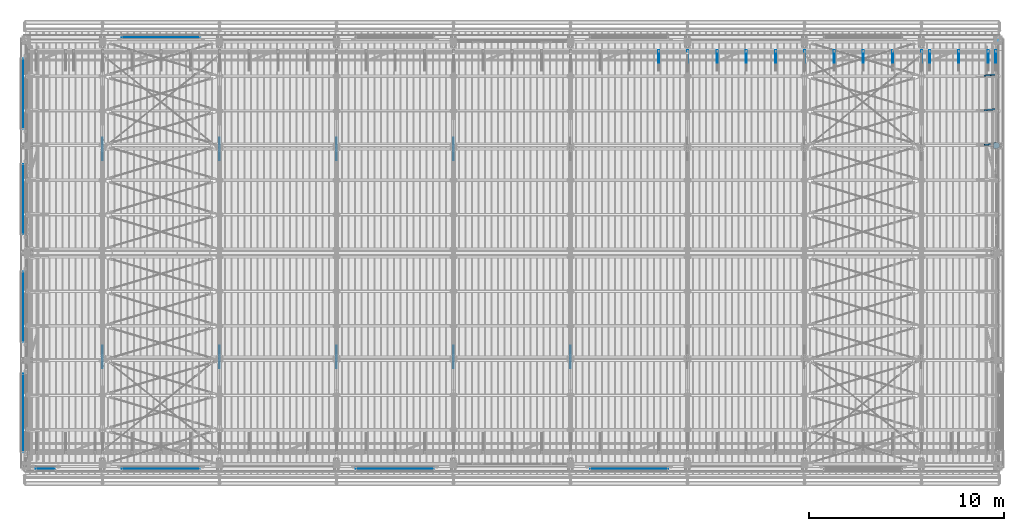
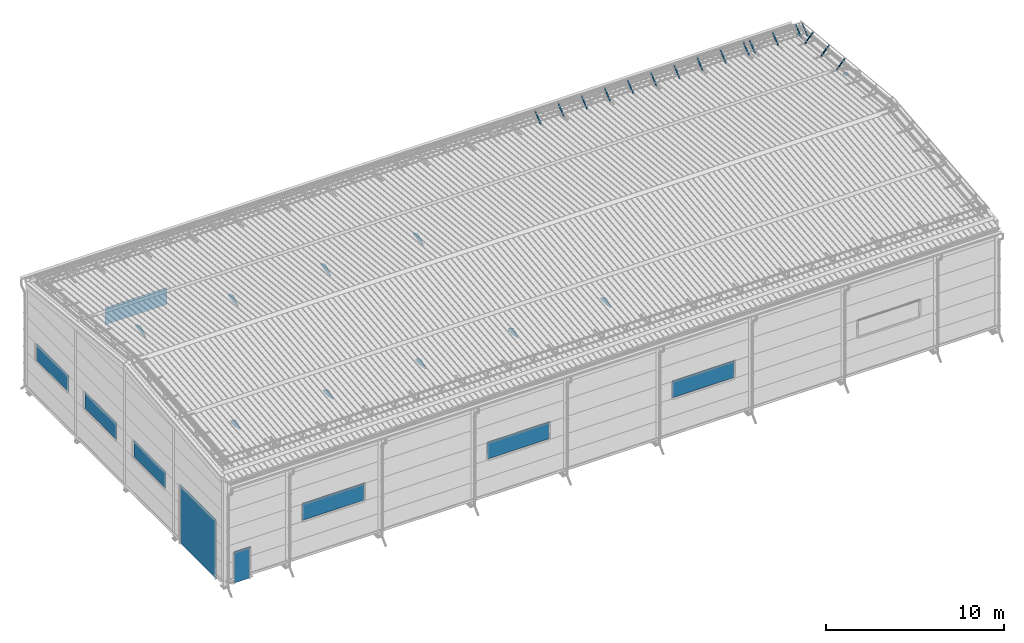
# One storey, part 105 of 709: 18 plates, 17 members, 2 beams, 37 elements without a shape of their own.
"""IFC4 building model written with IfcOpenShell, lengths in millimetres."""

from ifc_helpers import new_model, si_unit, direction, frame, origin_with_axes, place, context, subcontext, project, spatial, line, indexed_curve, outline, extrude, polygons, material, element, aggregate, save


model = new_model("IFC4")

# Units and contexts
model_context = context("Model", 3, precision=0.2, world=origin_with_axes(), true_north=direction((0.0, 1.0)))
body_context = subcontext(model_context, "Body", "Model", "MODEL_VIEW")
ifc_project = project(units=[si_unit("LENGTHUNIT", "METRE", prefix="MILLI"), si_unit("AREAUNIT", "SQUARE_METRE"), si_unit("VOLUMEUNIT", "CUBIC_METRE"), si_unit("MASSUNIT", "GRAM", prefix="KILO"), si_unit("TIMEUNIT", "SECOND"), si_unit("PLANEANGLEUNIT", "RADIAN"), si_unit("SOLIDANGLEUNIT", "STERADIAN"), si_unit("THERMODYNAMICTEMPERATUREUNIT", "DEGREE_CELSIUS"), si_unit("LUMINOUSINTENSITYUNIT", "LUMEN")], contexts=[model_context])

# Site, building, storey
site_placement = place(None, origin_with_axes())
site = spatial("IfcSite", under=ifc_project, at=site_placement, CompositionType="ELEMENT")
building_placement = place(site_placement, origin_with_axes())
building = spatial("IfcBuilding", under=site, at=building_placement, Name="Undefined", CompositionType="ELEMENT")
storey_placement = place(building_placement, origin_with_axes())
storey = spatial("IfcBuildingStorey", under=building, at=storey_placement, Name="Undefined", CompositionType="ELEMENT", Elevation=0.0)

# Assembly, beam
assembly_1_placement = place(storey_placement, frame((49920.0, 21920.0, -200.0), z_axis=(0.0, -1.0, 0.0), x_axis=(0.0, 0.0, 1.0)))
assembly_1 = element("IfcElementAssembly", 1, at=assembly_1_placement, inside=storey)
ifc_material_1 = material(Name="C355-6", Category="STEEL")
beam_1_placement = place(assembly_1_placement, frame((7216.36323, 48.5, -75.42283), z_axis=(0.9950371902, 0.0, -0.099503719), x_axis=(0.099503719, 0.0, 0.9950371902)))
beam_1 = element("IfcBeam", 2, at=beam_1_placement, material=ifc_material_1, ObjectType="454", context=body_context, shape_type="Tessellation", body=[
    polygons([(0.0, -123.5, 4.0), (0.0, 123.5, 4.0), (0.0, 123.5, -4.0), (0.0, -123.5, -4.0), (295.99751, -123.5, -4.0), (295.99751, -123.5, 4.0), (295.99751, 31.06708, 4.0), (166.2459, 123.5, 4.0), (166.2459, 123.5, -4.0), (295.99751, 31.06708, -4.0)], [[[1, 2, 3, 4]], [[1, 4, 5, 6]], [[2, 1, 6, 7, 8]], [[3, 2, 8, 9]], [[5, 4, 3, 9, 10]], [[6, 5, 10, 7]], [[9, 8, 7, 10]]], closed=True),
])
aggregate(assembly_1, [beam_1])

assembly_2_placement = place(storey_placement, frame((49851.0, 16500.0, -200.0), z_axis=(0.0, -1.0, 0.0), x_axis=(0.0, 0.0, 1.0)))
assembly_2 = element("IfcElementAssembly", 3, at=assembly_2_placement, inside=storey)
beam_2_placement = place(assembly_2_placement, frame((7777.2761, 0.0, 133.20719), z_axis=(0.9950371902, 0.0, -0.099503719), x_axis=(-0.099503719, 0.0, -0.9950371902)))
beam_2 = element("IfcBeam", 4, at=beam_2_placement, material=ifc_material_1, ObjectType="478", context=body_context, shape_type="Tessellation", body=[
    polygons([(0.0, -48.5, -6.0), (59.60596, -147.0, -6.0), (59.60596, -147.0, 6.0), (0.0, -48.5, 6.0), (0.0, 147.0, 6.0), (0.0, 147.0, -6.0), (309.74315, 147.0, 6.0), (309.74315, 147.0, -6.0), (309.74315, -48.5, 6.0), (309.74315, -48.5, -6.0), (209.3491, -147.0, -6.0), (209.3491, -147.0, 6.0)], [[[1, 2, 3, 4]], [[5, 6, 1, 4]], [[6, 5, 7, 8]], [[8, 7, 9, 10]], [[2, 1, 6, 8, 10, 11]], [[3, 2, 11, 12]], [[7, 5, 4, 3, 12, 9]], [[11, 10, 9, 12]]], closed=True),
])
aggregate(assembly_2, [beam_2])

# Assembly, member
assembly_3_placement = place(storey_placement, frame((49815.0, 20762.95162, 7589.66203), z_axis=(0.0, 0.6332377902, -0.7739572992), x_axis=(0.0, 0.7739572992, 0.6332377902)))
assembly_3 = element("IfcElementAssembly", 5, at=assembly_3_placement, inside=storey)
ifc_material_2 = material(Name="Steel_Undefined", Category="STEEL")
member_1_placement = place(assembly_3_placement, origin_with_axes())
member_1 = element("IfcMember", 6, at=member_1_placement, material=ifc_material_2, ObjectType="603", context=body_context, shape_type="Tessellation", body=[
    polygons([(0.0, -25.0, -20.0), (0.0, 25.0, -20.0), (848.52814, 25.0, -20.0), (848.52814, -25.0, -20.0), (40.0, 25.0, 20.0), (808.52814, 25.0, 20.0), (40.0, 22.5, 20.0), (808.52814, 22.5, 20.0), (2.5, 22.5, -17.5), (846.02814, 22.5, -17.5), (2.5, -22.5, -17.5), (846.02814, -22.5, -17.5), (40.0, -22.5, 20.0), (808.52814, -22.5, 20.0), (40.0, -25.0, 20.0), (808.52814, -25.0, 20.0)], [[[1, 2, 3, 4]], [[2, 5, 6, 3]], [[5, 7, 8, 6]], [[7, 9, 10, 8]], [[9, 11, 12, 10]], [[11, 13, 14, 12]], [[13, 15, 16, 14]], [[15, 1, 4, 16]], [[6, 8, 10, 12, 14, 16, 4, 3]], [[15, 13, 11, 9, 7, 5, 2, 1]]], closed=True),
])
aggregate(assembly_3, [member_1])

assembly_4_placement = place(storey_placement, frame((49415.0, 20762.95162, 7589.66203), z_axis=(0.0, 0.6332377902, -0.7739572992), x_axis=(0.0, 0.7739572992, 0.6332377902)))
assembly_4 = element("IfcElementAssembly", 7, at=assembly_4_placement, inside=storey)
member_2_placement = place(assembly_4_placement, origin_with_axes())
member_2 = element("IfcMember", 8, at=member_2_placement, material=ifc_material_2, ObjectType="603", context=body_context, shape_type="Tessellation", body=[
    polygons([(0.0, -25.0, -20.0), (0.0, 25.0, -20.0), (848.52814, 25.0, -20.0), (848.52814, -25.0, -20.0), (40.0, 25.0, 20.0), (808.52814, 25.0, 20.0), (40.0, 22.5, 20.0), (808.52814, 22.5, 20.0), (2.5, 22.5, -17.5), (846.02814, 22.5, -17.5), (2.5, -22.5, -17.5), (846.02814, -22.5, -17.5), (40.0, -22.5, 20.0), (808.52814, -22.5, 20.0), (40.0, -25.0, 20.0), (808.52814, -25.0, 20.0)], [[[1, 2, 3, 4]], [[2, 5, 6, 3]], [[5, 7, 8, 6]], [[7, 9, 10, 8]], [[9, 11, 12, 10]], [[11, 13, 14, 12]], [[13, 15, 16, 14]], [[15, 1, 4, 16]], [[6, 8, 10, 12, 14, 16, 4, 3]], [[15, 13, 11, 9, 7, 5, 2, 1]]], closed=True),
])
aggregate(assembly_4, [member_2])

assembly_5_placement = place(storey_placement, frame((47915.0, 20762.95162, 7589.66203), z_axis=(0.0, 0.6332377902, -0.7739572992), x_axis=(0.0, 0.7739572992, 0.6332377902)))
assembly_5 = element("IfcElementAssembly", 9, at=assembly_5_placement, inside=storey)
member_3_placement = place(assembly_5_placement, origin_with_axes())
member_3 = element("IfcMember", 10, at=member_3_placement, material=ifc_material_2, ObjectType="603", context=body_context, shape_type="Tessellation", body=[
    polygons([(0.0, -25.0, -20.0), (0.0, 25.0, -20.0), (848.52814, 25.0, -20.0), (848.52814, -25.0, -20.0), (40.0, 25.0, 20.0), (808.52814, 25.0, 20.0), (40.0, 22.5, 20.0), (808.52814, 22.5, 20.0), (2.5, 22.5, -17.5), (846.02814, 22.5, -17.5), (2.5, -22.5, -17.5), (846.02814, -22.5, -17.5), (40.0, -22.5, 20.0), (808.52814, -22.5, 20.0), (40.0, -25.0, 20.0), (808.52814, -25.0, 20.0)], [[[1, 2, 3, 4]], [[2, 5, 6, 3]], [[5, 7, 8, 6]], [[7, 9, 10, 8]], [[9, 11, 12, 10]], [[11, 13, 14, 12]], [[13, 15, 16, 14]], [[15, 1, 4, 16]], [[6, 8, 10, 12, 14, 16, 4, 3]], [[15, 13, 11, 9, 7, 5, 2, 1]]], closed=True),
])
aggregate(assembly_5, [member_3])

assembly_6_placement = place(storey_placement, frame((46415.0, 20762.95162, 7589.66203), z_axis=(0.0, 0.6332377902, -0.7739572992), x_axis=(0.0, 0.7739572992, 0.6332377902)))
assembly_6 = element("IfcElementAssembly", 11, at=assembly_6_placement, inside=storey)
member_4_placement = place(assembly_6_placement, origin_with_axes())
member_4 = element("IfcMember", 12, at=member_4_placement, material=ifc_material_2, ObjectType="603", context=body_context, shape_type="Tessellation", body=[
    polygons([(0.0, -25.0, -20.0), (0.0, 25.0, -20.0), (848.52814, 25.0, -20.0), (848.52814, -25.0, -20.0), (40.0, 25.0, 20.0), (808.52814, 25.0, 20.0), (40.0, 22.5, 20.0), (808.52814, 22.5, 20.0), (2.5, 22.5, -17.5), (846.02814, 22.5, -17.5), (2.5, -22.5, -17.5), (846.02814, -22.5, -17.5), (40.0, -22.5, 20.0), (808.52814, -22.5, 20.0), (40.0, -25.0, 20.0), (808.52814, -25.0, 20.0)], [[[1, 2, 3, 4]], [[2, 5, 6, 3]], [[5, 7, 8, 6]], [[7, 9, 10, 8]], [[9, 11, 12, 10]], [[11, 13, 14, 12]], [[13, 15, 16, 14]], [[15, 1, 4, 16]], [[6, 8, 10, 12, 14, 16, 4, 3]], [[15, 13, 11, 9, 7, 5, 2, 1]]], closed=True),
])
aggregate(assembly_6, [member_4])

assembly_7_placement = place(storey_placement, frame((46015.0, 20762.95162, 7589.66203), z_axis=(0.0, 0.6332377902, -0.7739572992), x_axis=(0.0, 0.7739572992, 0.6332377902)))
assembly_7 = element("IfcElementAssembly", 13, at=assembly_7_placement, inside=storey)
member_5_placement = place(assembly_7_placement, origin_with_axes())
member_5 = element("IfcMember", 14, at=member_5_placement, material=ifc_material_2, ObjectType="603", context=body_context, shape_type="Tessellation", body=[
    polygons([(0.0, -25.0, -20.0), (0.0, 25.0, -20.0), (848.52814, 25.0, -20.0), (848.52814, -25.0, -20.0), (40.0, 25.0, 20.0), (808.52814, 25.0, 20.0), (40.0, 22.5, 20.0), (808.52814, 22.5, 20.0), (2.5, 22.5, -17.5), (846.02814, 22.5, -17.5), (2.5, -22.5, -17.5), (846.02814, -22.5, -17.5), (40.0, -22.5, 20.0), (808.52814, -22.5, 20.0), (40.0, -25.0, 20.0), (808.52814, -25.0, 20.0)], [[[1, 2, 3, 4]], [[2, 5, 6, 3]], [[5, 7, 8, 6]], [[7, 9, 10, 8]], [[9, 11, 12, 10]], [[11, 13, 14, 12]], [[13, 15, 16, 14]], [[15, 1, 4, 16]], [[6, 8, 10, 12, 14, 16, 4, 3]], [[15, 13, 11, 9, 7, 5, 2, 1]]], closed=True),
])
aggregate(assembly_7, [member_5])

assembly_8_placement = place(storey_placement, frame((44515.0, 20762.95162, 7589.66203), z_axis=(0.0, 0.6332377902, -0.7739572992), x_axis=(0.0, 0.7739572992, 0.6332377902)))
assembly_8 = element("IfcElementAssembly", 15, at=assembly_8_placement, inside=storey)
member_6_placement = place(assembly_8_placement, origin_with_axes())
member_6 = element("IfcMember", 16, at=member_6_placement, material=ifc_material_2, ObjectType="603", context=body_context, shape_type="Tessellation", body=[
    polygons([(0.0, -25.0, -20.0), (0.0, 25.0, -20.0), (848.52814, 25.0, -20.0), (848.52814, -25.0, -20.0), (40.0, 25.0, 20.0), (808.52814, 25.0, 20.0), (40.0, 22.5, 20.0), (808.52814, 22.5, 20.0), (2.5, 22.5, -17.5), (846.02814, 22.5, -17.5), (2.5, -22.5, -17.5), (846.02814, -22.5, -17.5), (40.0, -22.5, 20.0), (808.52814, -22.5, 20.0), (40.0, -25.0, 20.0), (808.52814, -25.0, 20.0)], [[[1, 2, 3, 4]], [[2, 5, 6, 3]], [[5, 7, 8, 6]], [[7, 9, 10, 8]], [[9, 11, 12, 10]], [[11, 13, 14, 12]], [[13, 15, 16, 14]], [[15, 1, 4, 16]], [[6, 8, 10, 12, 14, 16, 4, 3]], [[15, 13, 11, 9, 7, 5, 2, 1]]], closed=True),
])
aggregate(assembly_8, [member_6])

assembly_9_placement = place(storey_placement, frame((43015.0, 20762.95162, 7589.66203), z_axis=(0.0, 0.6332377902, -0.7739572992), x_axis=(0.0, 0.7739572992, 0.6332377902)))
assembly_9 = element("IfcElementAssembly", 17, at=assembly_9_placement, inside=storey)
member_7_placement = place(assembly_9_placement, origin_with_axes())
member_7 = element("IfcMember", 18, at=member_7_placement, material=ifc_material_2, ObjectType="603", context=body_context, shape_type="Tessellation", body=[
    polygons([(0.0, -25.0, -20.0), (0.0, 25.0, -20.0), (848.52814, 25.0, -20.0), (848.52814, -25.0, -20.0), (40.0, 25.0, 20.0), (808.52814, 25.0, 20.0), (40.0, 22.5, 20.0), (808.52814, 22.5, 20.0), (2.5, 22.5, -17.5), (846.02814, 22.5, -17.5), (2.5, -22.5, -17.5), (846.02814, -22.5, -17.5), (40.0, -22.5, 20.0), (808.52814, -22.5, 20.0), (40.0, -25.0, 20.0), (808.52814, -25.0, 20.0)], [[[1, 2, 3, 4]], [[2, 5, 6, 3]], [[5, 7, 8, 6]], [[7, 9, 10, 8]], [[9, 11, 12, 10]], [[11, 13, 14, 12]], [[13, 15, 16, 14]], [[15, 1, 4, 16]], [[6, 8, 10, 12, 14, 16, 4, 3]], [[15, 13, 11, 9, 7, 5, 2, 1]]], closed=True),
])
aggregate(assembly_9, [member_7])

assembly_10_placement = place(storey_placement, frame((41515.0, 20762.95162, 7589.66203), z_axis=(0.0, 0.6332377902, -0.7739572992), x_axis=(0.0, 0.7739572992, 0.6332377902)))
assembly_10 = element("IfcElementAssembly", 19, at=assembly_10_placement, inside=storey)
member_8_placement = place(assembly_10_placement, origin_with_axes())
member_8 = element("IfcMember", 20, at=member_8_placement, material=ifc_material_2, ObjectType="603", context=body_context, shape_type="Tessellation", body=[
    polygons([(0.0, -25.0, -20.0), (0.0, 25.0, -20.0), (848.52814, 25.0, -20.0), (848.52814, -25.0, -20.0), (40.0, 25.0, 20.0), (808.52814, 25.0, 20.0), (40.0, 22.5, 20.0), (808.52814, 22.5, 20.0), (2.5, 22.5, -17.5), (846.02814, 22.5, -17.5), (2.5, -22.5, -17.5), (846.02814, -22.5, -17.5), (40.0, -22.5, 20.0), (808.52814, -22.5, 20.0), (40.0, -25.0, 20.0), (808.52814, -25.0, 20.0)], [[[1, 2, 3, 4]], [[2, 5, 6, 3]], [[5, 7, 8, 6]], [[7, 9, 10, 8]], [[9, 11, 12, 10]], [[11, 13, 14, 12]], [[13, 15, 16, 14]], [[15, 1, 4, 16]], [[6, 8, 10, 12, 14, 16, 4, 3]], [[15, 13, 11, 9, 7, 5, 2, 1]]], closed=True),
])
aggregate(assembly_10, [member_8])

assembly_11_placement = place(storey_placement, frame((40015.0, 20762.95162, 7589.66203), z_axis=(0.0, 0.6332377902, -0.7739572992), x_axis=(0.0, 0.7739572992, 0.6332377902)))
assembly_11 = element("IfcElementAssembly", 21, at=assembly_11_placement, inside=storey)
member_9_placement = place(assembly_11_placement, origin_with_axes())
member_9 = element("IfcMember", 22, at=member_9_placement, material=ifc_material_2, ObjectType="603", context=body_context, shape_type="Tessellation", body=[
    polygons([(0.0, -25.0, -20.0), (0.0, 25.0, -20.0), (848.52814, 25.0, -20.0), (848.52814, -25.0, -20.0), (40.0, 25.0, 20.0), (808.52814, 25.0, 20.0), (40.0, 22.5, 20.0), (808.52814, 22.5, 20.0), (2.5, 22.5, -17.5), (846.02814, 22.5, -17.5), (2.5, -22.5, -17.5), (846.02814, -22.5, -17.5), (40.0, -22.5, 20.0), (808.52814, -22.5, 20.0), (40.0, -25.0, 20.0), (808.52814, -25.0, 20.0)], [[[1, 2, 3, 4]], [[2, 5, 6, 3]], [[5, 7, 8, 6]], [[7, 9, 10, 8]], [[9, 11, 12, 10]], [[11, 13, 14, 12]], [[13, 15, 16, 14]], [[15, 1, 4, 16]], [[6, 8, 10, 12, 14, 16, 4, 3]], [[15, 13, 11, 9, 7, 5, 2, 1]]], closed=True),
])
aggregate(assembly_11, [member_9])

assembly_12_placement = place(storey_placement, frame((38515.0, 20762.95162, 7589.66203), z_axis=(0.0, 0.6332377902, -0.7739572992), x_axis=(0.0, 0.7739572992, 0.6332377902)))
assembly_12 = element("IfcElementAssembly", 23, at=assembly_12_placement, inside=storey)
member_10_placement = place(assembly_12_placement, origin_with_axes())
member_10 = element("IfcMember", 24, at=member_10_placement, material=ifc_material_2, ObjectType="603", context=body_context, shape_type="Tessellation", body=[
    polygons([(0.0, -25.0, -20.0), (0.0, 25.0, -20.0), (848.52814, 25.0, -20.0), (848.52814, -25.0, -20.0), (40.0, 25.0, 20.0), (808.52814, 25.0, 20.0), (40.0, 22.5, 20.0), (808.52814, 22.5, 20.0), (2.5, 22.5, -17.5), (846.02814, 22.5, -17.5), (2.5, -22.5, -17.5), (846.02814, -22.5, -17.5), (40.0, -22.5, 20.0), (808.52814, -22.5, 20.0), (40.0, -25.0, 20.0), (808.52814, -25.0, 20.0)], [[[1, 2, 3, 4]], [[2, 5, 6, 3]], [[5, 7, 8, 6]], [[7, 9, 10, 8]], [[9, 11, 12, 10]], [[11, 13, 14, 12]], [[13, 15, 16, 14]], [[15, 1, 4, 16]], [[6, 8, 10, 12, 14, 16, 4, 3]], [[15, 13, 11, 9, 7, 5, 2, 1]]], closed=True),
])
aggregate(assembly_12, [member_10])

assembly_13_placement = place(storey_placement, frame((37015.0, 20762.95162, 7589.66203), z_axis=(0.0, 0.6332377902, -0.7739572992), x_axis=(0.0, 0.7739572992, 0.6332377902)))
assembly_13 = element("IfcElementAssembly", 25, at=assembly_13_placement, inside=storey)
member_11_placement = place(assembly_13_placement, origin_with_axes())
member_11 = element("IfcMember", 26, at=member_11_placement, material=ifc_material_2, ObjectType="603", context=body_context, shape_type="Tessellation", body=[
    polygons([(0.0, -25.0, -20.0), (0.0, 25.0, -20.0), (848.52814, 25.0, -20.0), (848.52814, -25.0, -20.0), (40.0, 25.0, 20.0), (808.52814, 25.0, 20.0), (40.0, 22.5, 20.0), (808.52814, 22.5, 20.0), (2.5, 22.5, -17.5), (846.02814, 22.5, -17.5), (2.5, -22.5, -17.5), (846.02814, -22.5, -17.5), (40.0, -22.5, 20.0), (808.52814, -22.5, 20.0), (40.0, -25.0, 20.0), (808.52814, -25.0, 20.0)], [[[1, 2, 3, 4]], [[2, 5, 6, 3]], [[5, 7, 8, 6]], [[7, 9, 10, 8]], [[9, 11, 12, 10]], [[11, 13, 14, 12]], [[13, 15, 16, 14]], [[15, 1, 4, 16]], [[6, 8, 10, 12, 14, 16, 4, 3]], [[15, 13, 11, 9, 7, 5, 2, 1]]], closed=True),
])
aggregate(assembly_13, [member_11])

assembly_14_placement = place(storey_placement, frame((35515.0, 20762.95162, 7589.66203), z_axis=(0.0, 0.6332377902, -0.7739572992), x_axis=(0.0, 0.7739572992, 0.6332377902)))
assembly_14 = element("IfcElementAssembly", 27, at=assembly_14_placement, inside=storey)
member_12_placement = place(assembly_14_placement, origin_with_axes())
member_12 = element("IfcMember", 28, at=member_12_placement, material=ifc_material_2, ObjectType="603", context=body_context, shape_type="Tessellation", body=[
    polygons([(0.0, -25.0, -20.0), (0.0, 25.0, -20.0), (848.52814, 25.0, -20.0), (848.52814, -25.0, -20.0), (40.0, 25.0, 20.0), (808.52814, 25.0, 20.0), (40.0, 22.5, 20.0), (808.52814, 22.5, 20.0), (2.5, 22.5, -17.5), (846.02814, 22.5, -17.5), (2.5, -22.5, -17.5), (846.02814, -22.5, -17.5), (40.0, -22.5, 20.0), (808.52814, -22.5, 20.0), (40.0, -25.0, 20.0), (808.52814, -25.0, 20.0)], [[[1, 2, 3, 4]], [[2, 5, 6, 3]], [[5, 7, 8, 6]], [[7, 9, 10, 8]], [[9, 11, 12, 10]], [[11, 13, 14, 12]], [[13, 15, 16, 14]], [[15, 1, 4, 16]], [[6, 8, 10, 12, 14, 16, 4, 3]], [[15, 13, 11, 9, 7, 5, 2, 1]]], closed=True),
])
aggregate(assembly_14, [member_12])

assembly_15_placement = place(storey_placement, frame((34015.0, 20762.95162, 7589.66203), z_axis=(0.0, 0.6332377902, -0.7739572992), x_axis=(0.0, 0.7739572992, 0.6332377902)))
assembly_15 = element("IfcElementAssembly", 29, at=assembly_15_placement, inside=storey)
member_13_placement = place(assembly_15_placement, origin_with_axes())
member_13 = element("IfcMember", 30, at=member_13_placement, material=ifc_material_2, ObjectType="603", context=body_context, shape_type="Tessellation", body=[
    polygons([(0.0, -25.0, -20.0), (0.0, 25.0, -20.0), (848.52814, 25.0, -20.0), (848.52814, -25.0, -20.0), (40.0, 25.0, 20.0), (808.52814, 25.0, 20.0), (40.0, 22.5, 20.0), (808.52814, 22.5, 20.0), (2.5, 22.5, -17.5), (846.02814, 22.5, -17.5), (2.5, -22.5, -17.5), (846.02814, -22.5, -17.5), (40.0, -22.5, 20.0), (808.52814, -22.5, 20.0), (40.0, -25.0, 20.0), (808.52814, -25.0, 20.0)], [[[1, 2, 3, 4]], [[2, 5, 6, 3]], [[5, 7, 8, 6]], [[7, 9, 10, 8]], [[9, 11, 12, 10]], [[11, 13, 14, 12]], [[13, 15, 16, 14]], [[15, 1, 4, 16]], [[6, 8, 10, 12, 14, 16, 4, 3]], [[15, 13, 11, 9, 7, 5, 2, 1]]], closed=True),
])
aggregate(assembly_15, [member_13])

assembly_16_placement = place(storey_placement, frame((32515.0, 20762.95162, 7589.66203), z_axis=(0.0, 0.6332377902, -0.7739572992), x_axis=(0.0, 0.7739572992, 0.6332377902)))
assembly_16 = element("IfcElementAssembly", 31, at=assembly_16_placement, inside=storey)
member_14_placement = place(assembly_16_placement, origin_with_axes())
member_14 = element("IfcMember", 32, at=member_14_placement, material=ifc_material_2, ObjectType="603", context=body_context, shape_type="Tessellation", body=[
    polygons([(0.0, -25.0, -20.0), (0.0, 25.0, -20.0), (848.52814, 25.0, -20.0), (848.52814, -25.0, -20.0), (40.0, 25.0, 20.0), (808.52814, 25.0, 20.0), (40.0, 22.5, 20.0), (808.52814, 22.5, 20.0), (2.5, 22.5, -17.5), (846.02814, 22.5, -17.5), (2.5, -22.5, -17.5), (846.02814, -22.5, -17.5), (40.0, -22.5, 20.0), (808.52814, -22.5, 20.0), (40.0, -25.0, 20.0), (808.52814, -25.0, 20.0)], [[[1, 2, 3, 4]], [[2, 5, 6, 3]], [[5, 7, 8, 6]], [[7, 9, 10, 8]], [[9, 11, 12, 10]], [[11, 13, 14, 12]], [[13, 15, 16, 14]], [[15, 1, 4, 16]], [[6, 8, 10, 12, 14, 16, 4, 3]], [[15, 13, 11, 9, 7, 5, 2, 1]]], closed=True),
])
aggregate(assembly_16, [member_14])

assembly_17_placement = place(storey_placement, frame((49229.14214, 16543.36948, 8011.62024), z_axis=(0.7071067814, -0.0703597545, -0.7035975445), x_axis=(0.707106781, 0.070359754, 0.703597545)))
assembly_17 = element("IfcElementAssembly", 33, at=assembly_17_placement, inside=storey)
member_15_placement = place(assembly_17_placement, origin_with_axes())
member_15 = element("IfcMember", 34, at=member_15_placement, material=ifc_material_2, ObjectType="603", context=body_context, shape_type="Tessellation", body=[
    polygons([(0.0, -25.0, -20.0), (0.0, 25.0, -20.0), (848.52814, 25.0, -20.0), (848.52814, -25.0, -20.0), (40.0, 25.0, 20.0), (808.52814, 25.0, 20.0), (40.0, 22.5, 20.0), (808.52814, 22.5, 20.0), (2.5, 22.5, -17.5), (846.02814, 22.5, -17.5), (2.5, -22.5, -17.5), (846.02814, -22.5, -17.5), (40.0, -22.5, 20.0), (808.52814, -22.5, 20.0), (40.0, -25.0, 20.0), (808.52814, -25.0, 20.0)], [[[1, 2, 3, 4]], [[2, 5, 6, 3]], [[5, 7, 8, 6]], [[7, 9, 10, 8]], [[9, 11, 12, 10]], [[11, 13, 14, 12]], [[13, 15, 16, 14]], [[15, 1, 4, 16]], [[6, 8, 10, 12, 14, 16, 4, 3]], [[15, 13, 11, 9, 7, 5, 2, 1]]], closed=True),
])
aggregate(assembly_17, [member_15])

assembly_18_placement = place(storey_placement, frame((49229.14214, 18320.06923, 7833.95027), z_axis=(0.7071067814, -0.0703597545, -0.7035975445), x_axis=(0.707106781, 0.070359754, 0.703597545)))
assembly_18 = element("IfcElementAssembly", 35, at=assembly_18_placement, inside=storey)
member_16_placement = place(assembly_18_placement, origin_with_axes())
member_16 = element("IfcMember", 36, at=member_16_placement, material=ifc_material_2, ObjectType="603", context=body_context, shape_type="Tessellation", body=[
    polygons([(0.0, -25.0, -20.0), (0.0, 25.0, -20.0), (848.52814, 25.0, -20.0), (848.52814, -25.0, -20.0), (40.0, 25.0, 20.0), (808.52814, 25.0, 20.0), (40.0, 22.5, 20.0), (808.52814, 22.5, 20.0), (2.5, 22.5, -17.5), (846.02814, 22.5, -17.5), (2.5, -22.5, -17.5), (846.02814, -22.5, -17.5), (40.0, -22.5, 20.0), (808.52814, -22.5, 20.0), (40.0, -25.0, 20.0), (808.52814, -25.0, 20.0)], [[[1, 2, 3, 4]], [[2, 5, 6, 3]], [[5, 7, 8, 6]], [[7, 9, 10, 8]], [[9, 11, 12, 10]], [[11, 13, 14, 12]], [[13, 15, 16, 14]], [[15, 1, 4, 16]], [[6, 8, 10, 12, 14, 16, 4, 3]], [[15, 13, 11, 9, 7, 5, 2, 1]]], closed=True),
])
aggregate(assembly_18, [member_16])

assembly_19_placement = place(storey_placement, frame((49229.14214, 20096.76898, 7656.28029), z_axis=(0.7071067814, -0.0703597545, -0.7035975445), x_axis=(0.707106781, 0.070359754, 0.703597545)))
assembly_19 = element("IfcElementAssembly", 37, at=assembly_19_placement, inside=storey)
member_17_placement = place(assembly_19_placement, origin_with_axes())
member_17 = element("IfcMember", 38, at=member_17_placement, material=ifc_material_2, ObjectType="603", context=body_context, shape_type="Tessellation", body=[
    polygons([(0.0, -25.0, -20.0), (0.0, 25.0, -20.0), (848.52814, 25.0, -20.0), (848.52814, -25.0, -20.0), (40.0, 25.0, 20.0), (808.52814, 25.0, 20.0), (40.0, 22.5, 20.0), (808.52814, 22.5, 20.0), (2.5, 22.5, -17.5), (846.02814, 22.5, -17.5), (2.5, -22.5, -17.5), (846.02814, -22.5, -17.5), (40.0, -22.5, 20.0), (808.52814, -22.5, 20.0), (40.0, -25.0, 20.0), (808.52814, -25.0, 20.0)], [[[1, 2, 3, 4]], [[2, 5, 6, 3]], [[5, 7, 8, 6]], [[7, 9, 10, 8]], [[9, 11, 12, 10]], [[11, 13, 14, 12]], [[13, 15, 16, 14]], [[15, 1, 4, 16]], [[6, 8, 10, 12, 14, 16, 4, 3]], [[15, 13, 11, 9, 7, 5, 2, 1]]], closed=True),
])
aggregate(assembly_19, [member_17])

# Assembly, plate
assembly_20_placement = place(storey_placement, frame((16000.0, 5668.61344, 5980.00002), z_axis=(1.0, 0.0, 0.0), x_axis=(0.0, 1.0, 0.0)))
assembly_20 = element("IfcElementAssembly", 39, at=assembly_20_placement, inside=storey)
plate_1_placement = place(assembly_20_placement, origin_with_axes())
plate_1 = element("IfcPlate", 40, at=plate_1_placement, material=ifc_material_1, ObjectType="445", context=body_context, shape_type="SolidModel", body=[
    extrude(outline(indexed_curve([(0.0, 0.0), (564.38656, 0.0), (564.38656, 130.0), (45.08656, 480.0), (-84.91344, 480.0), (-542.75823, 241.12615), (-568.25333, 113.65067)], segments=[line(1, 2, 3, 4, 5, 6, 7, 1)])), frame((0.0, 0.0, 4.0), z_axis=(0.0, 0.0, 1.0), x_axis=(1.0, 0.0, 0.0)), (0.0, 0.0, -1.0), 8.0),
])
aggregate(assembly_20, [plate_1])

assembly_21_placement = place(storey_placement, frame((16000.0, 16331.38656, 5980.00002), z_axis=(-1.0, 0.0, 0.0), x_axis=(0.0, -1.0, 0.0)))
assembly_21 = element("IfcElementAssembly", 41, at=assembly_21_placement, inside=storey)
plate_2_placement = place(assembly_21_placement, origin_with_axes())
plate_2 = element("IfcPlate", 42, at=plate_2_placement, material=ifc_material_1, ObjectType="448", context=body_context, shape_type="SolidModel", body=[
    extrude(outline(indexed_curve([(0.0, 0.0), (564.38656, 0.0), (564.38656, 130.0), (48.68656, 480.0), (-81.31344, 480.0), (-542.75823, 241.12615), (-568.25333, 113.65067)], segments=[line(1, 2, 3, 4, 5, 6, 7, 1)])), frame((0.0, 0.0, 4.0), z_axis=(0.0, 0.0, 1.0), x_axis=(1.0, 0.0, 0.0)), (0.0, 0.0, -1.0), 8.0),
])
aggregate(assembly_21, [plate_2])

assembly_22_placement = place(storey_placement, frame((22000.0, 5668.61344, 5980.00002), z_axis=(1.0, 0.0, 0.0), x_axis=(0.0, 1.0, 0.0)))
assembly_22 = element("IfcElementAssembly", 43, at=assembly_22_placement, inside=storey)
plate_3_placement = place(assembly_22_placement, origin_with_axes())
plate_3 = element("IfcPlate", 44, at=plate_3_placement, material=ifc_material_1, ObjectType="445", context=body_context, shape_type="SolidModel", body=[
    extrude(outline(indexed_curve([(0.0, 0.0), (564.38656, 0.0), (564.38656, 130.0), (45.08656, 480.0), (-84.91344, 480.0), (-542.75823, 241.12615), (-568.25333, 113.65067)], segments=[line(1, 2, 3, 4, 5, 6, 7, 1)])), frame((0.0, 0.0, 4.0), z_axis=(0.0, 0.0, 1.0), x_axis=(1.0, 0.0, 0.0)), (0.0, 0.0, -1.0), 8.0),
])
aggregate(assembly_22, [plate_3])

assembly_23_placement = place(storey_placement, frame((22000.0, 16331.38656, 5980.00002), z_axis=(-1.0, 0.0, 0.0), x_axis=(0.0, -1.0, 0.0)))
assembly_23 = element("IfcElementAssembly", 45, at=assembly_23_placement, inside=storey)
plate_4_placement = place(assembly_23_placement, origin_with_axes())
plate_4 = element("IfcPlate", 46, at=plate_4_placement, material=ifc_material_1, ObjectType="448", context=body_context, shape_type="SolidModel", body=[
    extrude(outline(indexed_curve([(0.0, 0.0), (564.38656, 0.0), (564.38656, 130.0), (48.68656, 480.0), (-81.31344, 480.0), (-542.75823, 241.12615), (-568.25333, 113.65067)], segments=[line(1, 2, 3, 4, 5, 6, 7, 1)])), frame((0.0, 0.0, 4.0), z_axis=(0.0, 0.0, 1.0), x_axis=(1.0, 0.0, 0.0)), (0.0, 0.0, -1.0), 8.0),
])
aggregate(assembly_23, [plate_4])

assembly_24_placement = place(storey_placement, frame((28000.0, 5668.61344, 5980.00002), z_axis=(1.0, 0.0, 0.0), x_axis=(0.0, 1.0, 0.0)))
assembly_24 = element("IfcElementAssembly", 47, at=assembly_24_placement, inside=storey)
plate_5_placement = place(assembly_24_placement, origin_with_axes())
plate_5 = element("IfcPlate", 48, at=plate_5_placement, material=ifc_material_1, ObjectType="445", context=body_context, shape_type="SolidModel", body=[
    extrude(outline(indexed_curve([(0.0, 0.0), (564.38656, 0.0), (564.38656, 130.0), (45.08656, 480.0), (-84.91344, 480.0), (-542.75823, 241.12615), (-568.25333, 113.65067)], segments=[line(1, 2, 3, 4, 5, 6, 7, 1)])), frame((0.0, 0.0, 4.0), z_axis=(0.0, 0.0, 1.0), x_axis=(1.0, 0.0, 0.0)), (0.0, 0.0, -1.0), 8.0),
])
aggregate(assembly_24, [plate_5])

assembly_25_placement = place(storey_placement, frame((4000.0, 5668.61344, 5980.00002), z_axis=(1.0, 0.0, 0.0), x_axis=(0.0, 1.0, 0.0)))
assembly_25 = element("IfcElementAssembly", 49, at=assembly_25_placement, inside=storey)
plate_6_placement = place(assembly_25_placement, origin_with_axes())
plate_6 = element("IfcPlate", 50, at=plate_6_placement, material=ifc_material_1, ObjectType="445", context=body_context, shape_type="SolidModel", body=[
    extrude(outline(indexed_curve([(0.0, 0.0), (564.38656, 0.0), (564.38656, 130.0), (45.08656, 480.0), (-84.91344, 480.0), (-542.75823, 241.12615), (-568.25333, 113.65067)], segments=[line(1, 2, 3, 4, 5, 6, 7, 1)])), frame((0.0, 0.0, 4.0), z_axis=(0.0, 0.0, 1.0), x_axis=(1.0, 0.0, 0.0)), (0.0, 0.0, -1.0), 8.0),
])
aggregate(assembly_25, [plate_6])

assembly_26_placement = place(storey_placement, frame((4000.0, 16331.38656, 5980.00002), z_axis=(-1.0, 0.0, 0.0), x_axis=(0.0, -1.0, 0.0)))
assembly_26 = element("IfcElementAssembly", 51, at=assembly_26_placement, inside=storey)
plate_7_placement = place(assembly_26_placement, origin_with_axes())
plate_7 = element("IfcPlate", 52, at=plate_7_placement, material=ifc_material_1, ObjectType="448", context=body_context, shape_type="SolidModel", body=[
    extrude(outline(indexed_curve([(0.0, 0.0), (564.38656, 0.0), (564.38656, 130.0), (48.68656, 480.0), (-81.31344, 480.0), (-542.75823, 241.12615), (-568.25333, 113.65067)], segments=[line(1, 2, 3, 4, 5, 6, 7, 1)])), frame((0.0, 0.0, 4.0), z_axis=(0.0, 0.0, 1.0), x_axis=(1.0, 0.0, 0.0)), (0.0, 0.0, -1.0), 8.0),
])
aggregate(assembly_26, [plate_7])

assembly_27_placement = place(storey_placement, frame((10000.0, 5668.61344, 5980.00002), z_axis=(1.0, 0.0, 0.0), x_axis=(0.0, 1.0, 0.0)))
assembly_27 = element("IfcElementAssembly", 53, at=assembly_27_placement, inside=storey)
plate_8_placement = place(assembly_27_placement, origin_with_axes())
plate_8 = element("IfcPlate", 54, at=plate_8_placement, material=ifc_material_1, ObjectType="445", context=body_context, shape_type="SolidModel", body=[
    extrude(outline(indexed_curve([(0.0, 0.0), (564.38656, 0.0), (564.38656, 130.0), (45.08656, 480.0), (-84.91344, 480.0), (-542.75823, 241.12615), (-568.25333, 113.65067)], segments=[line(1, 2, 3, 4, 5, 6, 7, 1)])), frame((0.0, 0.0, 4.0), z_axis=(0.0, 0.0, 1.0), x_axis=(1.0, 0.0, 0.0)), (0.0, 0.0, -1.0), 8.0),
])
aggregate(assembly_27, [plate_8])

assembly_28_placement = place(storey_placement, frame((10000.0, 16331.38656, 5980.00002), z_axis=(-1.0, 0.0, 0.0), x_axis=(0.0, -1.0, 0.0)))
assembly_28 = element("IfcElementAssembly", 55, at=assembly_28_placement, inside=storey)
plate_9_placement = place(assembly_28_placement, origin_with_axes())
plate_9 = element("IfcPlate", 56, at=plate_9_placement, material=ifc_material_1, ObjectType="448", context=body_context, shape_type="SolidModel", body=[
    extrude(outline(indexed_curve([(0.0, 0.0), (564.38656, 0.0), (564.38656, 130.0), (48.68656, 480.0), (-81.31344, 480.0), (-542.75823, 241.12615), (-568.25333, 113.65067)], segments=[line(1, 2, 3, 4, 5, 6, 7, 1)])), frame((0.0, 0.0, 4.0), z_axis=(0.0, 0.0, 1.0), x_axis=(1.0, 0.0, 0.0)), (0.0, 0.0, -1.0), 8.0),
])
aggregate(assembly_28, [plate_9])

assembly_29_placement = place(storey_placement, frame((580.0, -60.0, -50.0), z_axis=(0.0, -1.0, 0.0), x_axis=(1.0, 0.0, 0.0)))
assembly_29 = element("IfcElementAssembly", 57, at=assembly_29_placement, inside=storey, Name="Opening")
ifc_material_3 = material()
plate_10_placement = place(assembly_29_placement, origin_with_axes())
plate_10 = element("IfcPlate", 58, at=plate_10_placement, material=ifc_material_3, Name="Opening", ObjectType="OP-9", context=body_context, shape_type="SolidModel", body=[
    extrude(outline(indexed_curve([(0.0, 0.0), (1000.0, 0.0), (1000.0, 2150.0), (0.0, 2150.0)], segments=[line(1, 2, 3, 4, 1)])), frame((0.0, 0.0, 5.0), z_axis=(0.0, 0.0, 1.0), x_axis=(1.0, 0.0, 0.0)), (0.0, 0.0, -1.0), 10.0),
])
aggregate(assembly_29, [plate_10])

assembly_30_placement = place(storey_placement, frame((5000.0, -60.0, 2700.0), z_axis=(0.0, -1.0, 0.0), x_axis=(1.0, 0.0, 0.0)))
assembly_30 = element("IfcElementAssembly", 59, at=assembly_30_placement, inside=storey, Name="Opening")
plate_11_placement = place(assembly_30_placement, origin_with_axes())
plate_11 = element("IfcPlate", 60, at=plate_11_placement, material=ifc_material_3, Name="Opening", ObjectType="OP-10", context=body_context, shape_type="SolidModel", body=[
    extrude(outline(indexed_curve([(0.0, 0.0), (4000.0, 0.0), (4000.0, 1170.0), (0.0, 1170.0)], segments=[line(1, 2, 3, 4, 1)])), frame((0.0, 0.0, 5.0), z_axis=(0.0, 0.0, 1.0), x_axis=(1.0, 0.0, 0.0)), (0.0, 0.0, -1.0), 10.0),
])
aggregate(assembly_30, [plate_11])

assembly_31_placement = place(storey_placement, frame((17000.0, -60.0, 2700.0), z_axis=(0.0, -1.0, 0.0), x_axis=(1.0, 0.0, 0.0)))
assembly_31 = element("IfcElementAssembly", 61, at=assembly_31_placement, inside=storey, Name="Opening")
plate_12_placement = place(assembly_31_placement, origin_with_axes())
plate_12 = element("IfcPlate", 62, at=plate_12_placement, material=ifc_material_3, Name="Opening", ObjectType="OP-10", context=body_context, shape_type="SolidModel", body=[
    extrude(outline(indexed_curve([(0.0, 0.0), (4000.0, 0.0), (4000.0, 1170.0), (0.0, 1170.0)], segments=[line(1, 2, 3, 4, 1)])), frame((0.0, 0.0, 5.0), z_axis=(0.0, 0.0, 1.0), x_axis=(1.0, 0.0, 0.0)), (0.0, 0.0, -1.0), 10.0),
])
aggregate(assembly_31, [plate_12])

assembly_32_placement = place(storey_placement, frame((29000.0, -60.0, 2700.0), z_axis=(0.0, -1.0, 0.0), x_axis=(1.0, 0.0, 0.0)))
assembly_32 = element("IfcElementAssembly", 63, at=assembly_32_placement, inside=storey, Name="Opening")
plate_13_placement = place(assembly_32_placement, origin_with_axes())
plate_13 = element("IfcPlate", 64, at=plate_13_placement, material=ifc_material_3, Name="Opening", ObjectType="OP-10", context=body_context, shape_type="SolidModel", body=[
    extrude(outline(indexed_curve([(0.0, 0.0), (4000.0, 0.0), (4000.0, 1170.0), (0.0, 1170.0)], segments=[line(1, 2, 3, 4, 1)])), frame((0.0, 0.0, 5.0), z_axis=(0.0, 0.0, 1.0), x_axis=(1.0, 0.0, 0.0)), (0.0, 0.0, -1.0), 10.0),
])
aggregate(assembly_32, [plate_13])

assembly_33_placement = place(storey_placement, frame((5000.0, 22060.0, 2700.0), z_axis=(0.0, -1.0, 0.0), x_axis=(1.0, 0.0, 0.0)))
assembly_33 = element("IfcElementAssembly", 65, at=assembly_33_placement, inside=storey, Name="Opening")
plate_14_placement = place(assembly_33_placement, origin_with_axes())
plate_14 = element("IfcPlate", 66, at=plate_14_placement, material=ifc_material_3, Name="Opening", ObjectType="OP-10", context=body_context, shape_type="SolidModel", body=[
    extrude(outline(indexed_curve([(0.0, 0.0), (4000.0, 0.0), (4000.0, 1170.0), (0.0, 1170.0)], segments=[line(1, 2, 3, 4, 1)])), frame((0.0, 0.0, 5.0), z_axis=(0.0, 0.0, 1.0), x_axis=(1.0, 0.0, 0.0)), (0.0, 0.0, -1.0), 10.0),
])
aggregate(assembly_33, [plate_14])

assembly_34_placement = place(storey_placement, frame((-60.0, 800.0, -50.0), z_axis=(1.0, 0.0, 0.0), x_axis=(0.0, 1.0, 0.0)))
assembly_34 = element("IfcElementAssembly", 67, at=assembly_34_placement, inside=storey, Name="Opening")
plate_15_placement = place(assembly_34_placement, origin_with_axes())
plate_15 = element("IfcPlate", 68, at=plate_15_placement, material=ifc_material_3, Name="Opening", ObjectType="OP-11", context=body_context, shape_type="SolidModel", body=[
    extrude(outline(indexed_curve([(0.0, 0.0), (4000.0, 0.0), (4000.0, 4050.0), (0.0, 4050.0)], segments=[line(1, 2, 3, 4, 1)])), frame((0.0, 0.0, 5.0), z_axis=(0.0, 0.0, 1.0), x_axis=(1.0, 0.0, 0.0)), (0.0, 0.0, -1.0), 10.0),
])
aggregate(assembly_34, [plate_15])

assembly_35_placement = place(storey_placement, frame((-60.0, 6450.0, 2700.0), z_axis=(1.0, 0.0, 0.0), x_axis=(0.0, 1.0, 0.0)))
assembly_35 = element("IfcElementAssembly", 69, at=assembly_35_placement, inside=storey, Name="Opening")
plate_16_placement = place(assembly_35_placement, origin_with_axes())
plate_16 = element("IfcPlate", 70, at=plate_16_placement, material=ifc_material_3, Name="Opening", ObjectType="OP-12", context=body_context, shape_type="SolidModel", body=[
    extrude(outline(indexed_curve([(0.0, 0.0), (3600.0, 0.0), (3600.0, 1170.0), (0.0, 1170.0)], segments=[line(1, 2, 3, 4, 1)])), frame((0.0, 0.0, 5.0), z_axis=(0.0, 0.0, 1.0), x_axis=(1.0, 0.0, 0.0)), (0.0, 0.0, -1.0), 10.0),
])
aggregate(assembly_35, [plate_16])

assembly_36_placement = place(storey_placement, frame((-60.0, 11950.0, 2700.0), z_axis=(1.0, 0.0, 0.0), x_axis=(0.0, 1.0, 0.0)))
assembly_36 = element("IfcElementAssembly", 71, at=assembly_36_placement, inside=storey, Name="Opening")
plate_17_placement = place(assembly_36_placement, origin_with_axes())
plate_17 = element("IfcPlate", 72, at=plate_17_placement, material=ifc_material_3, Name="Opening", ObjectType="OP-12", context=body_context, shape_type="SolidModel", body=[
    extrude(outline(indexed_curve([(0.0, 0.0), (3600.0, 0.0), (3600.0, 1170.0), (0.0, 1170.0)], segments=[line(1, 2, 3, 4, 1)])), frame((0.0, 0.0, 5.0), z_axis=(0.0, 0.0, 1.0), x_axis=(1.0, 0.0, 0.0)), (0.0, 0.0, -1.0), 10.0),
])
aggregate(assembly_36, [plate_17])

assembly_37_placement = place(storey_placement, frame((-60.0, 17370.0, 2700.0), z_axis=(1.0, 0.0, 0.0), x_axis=(0.0, 1.0, 0.0)))
assembly_37 = element("IfcElementAssembly", 73, at=assembly_37_placement, inside=storey, Name="Opening")
plate_18_placement = place(assembly_37_placement, origin_with_axes())
plate_18 = element("IfcPlate", 74, at=plate_18_placement, material=ifc_material_3, Name="Opening", ObjectType="OP-12", context=body_context, shape_type="SolidModel", body=[
    extrude(outline(indexed_curve([(0.0, 0.0), (3600.0, 0.0), (3600.0, 1170.0), (0.0, 1170.0)], segments=[line(1, 2, 3, 4, 1)])), frame((0.0, 0.0, 5.0), z_axis=(0.0, 0.0, 1.0), x_axis=(1.0, 0.0, 0.0)), (0.0, 0.0, -1.0), 10.0),
])
aggregate(assembly_37, [plate_18])

save(model, "model.ifc")
